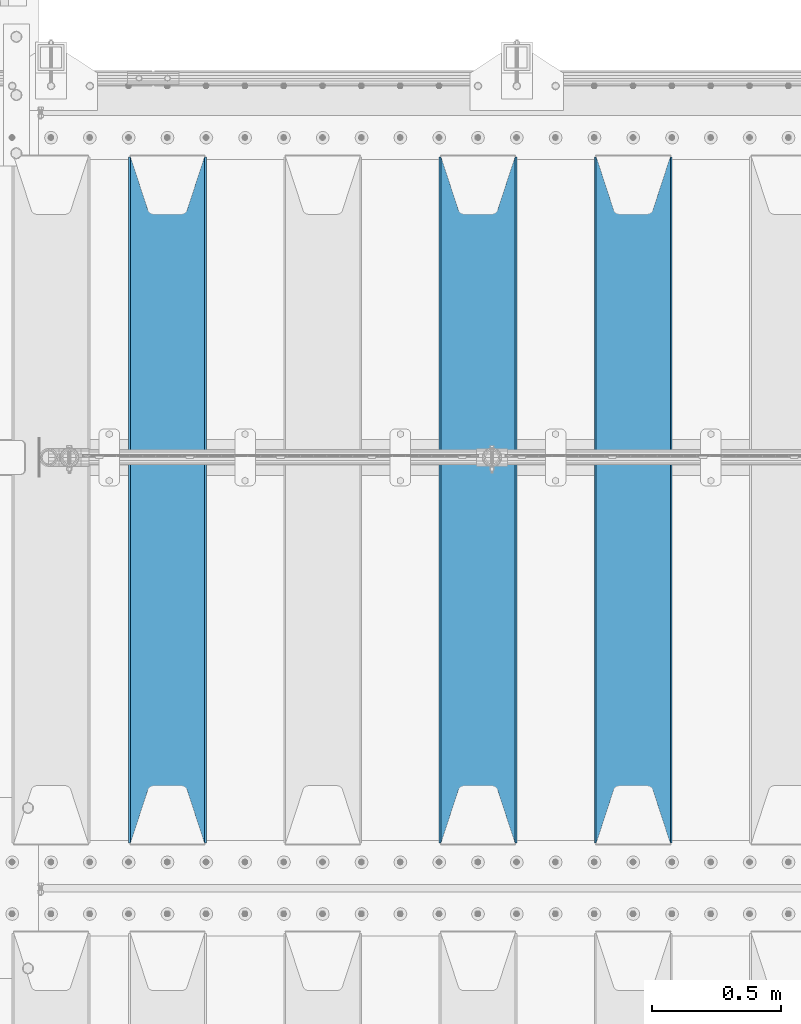
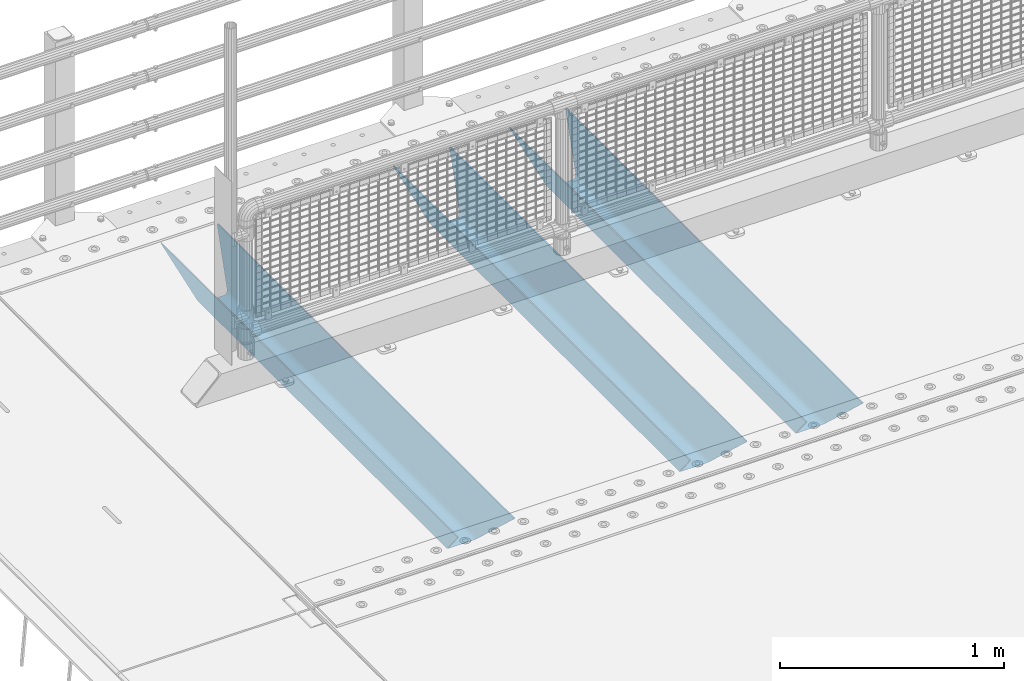
# One storey, part 114 of 242: 3 beams.
"""IFC2X3 building model written with IfcOpenShell, lengths in millimetres."""

from ifc_helpers import new_model, si_unit, frame, origin_with_axes, place, context, subcontext, project, spatial, faceted_brep, material, type_object, element, save


model = new_model("IFC2X3")

# Units and contexts
model_context = context("Model", 3, precision=1e-05, world=origin_with_axes())
body_context = subcontext(model_context, "Body", "Model", "MODEL_VIEW")
ifc_project = project(units=[si_unit("LENGTHUNIT", "METRE", prefix="MILLI"), si_unit("AREAUNIT", "SQUARE_METRE"), si_unit("VOLUMEUNIT", "CUBIC_METRE"), si_unit("MASSUNIT", "GRAM", prefix="KILO"), si_unit("TIMEUNIT", "SECOND"), si_unit("PLANEANGLEUNIT", "RADIAN"), si_unit("SOLIDANGLEUNIT", "STERADIAN"), si_unit("THERMODYNAMICTEMPERATUREUNIT", "DEGREE_CELSIUS"), si_unit("LUMINOUSINTENSITYUNIT", "LUMEN")], contexts=[model_context])

# Site, building, storey
site_placement = place(None, origin_with_axes())
site = spatial("IfcSite", under=ifc_project, at=site_placement, CompositionType="ELEMENT")
building_placement = place(site_placement, origin_with_axes())
building = spatial("IfcBuilding", under=site, at=building_placement, Name="Standard", CompositionType="ELEMENT")
storey_placement = place(building_placement, origin_with_axes())
storey = spatial("IfcBuildingStorey", under=building, at=storey_placement, Name="Undefined", CompositionType="ELEMENT", Elevation=0.0)

# Beams
ifc_material = material(Name="STEEL/S355N")
beam_type = type_object("IfcBeamType", PredefinedType="NOTDEFINED")
beam_1_placement = place(storey_placement, frame((-39650.0, -20825.0, -115.0), z_axis=(0.0, 0.0, 1.0), x_axis=(0.0, 1.0, 0.0)))
element("IfcBeam", 1, at=beam_1_placement, inside=storey, type_object=beam_type, material=ifc_material, context=body_context, shape_type="Brep", body=[
    faceted_brep([(0.0, 150.0, 115.0), (0.0, 143.689999999999, 115.0), (2650.00000000297, 143.689999999999, 115.0), (2650.00000000297, 150.0, 115.0), (2650.00000000297, 142.059565218402, 110.000000003099), (2650.00000000297, 148.369565218403, 110.000000003099), (2441.90079219209, -80.1103600731112, -98.0992078077845), (2437.7588105432, -77.5672621345584, -102.241189456673), (2434.06523489747, -74.4080125315522, -105.934765102404), (2430.91086095089, -70.710272125576, -109.089139048974), (2428.37322971128, -66.5649389910068, -111.626770288588), (2426.51472138055, -62.0739139532889, -113.485278619323), (2425.38102192092, -57.3475956567672, -114.618978078955), (2424.99999999987, -52.5021667386536, -115.0), (2424.99999999987, 52.5021667386536, -115.0), (2425.38102192092, 57.3475956567672, -114.618978078955), (2426.51472138055, 62.0739139532889, -113.485278619323), (2428.37322971128, 66.5649389910068, -111.626770288588), (2430.91086095089, 70.710272125576, -109.089139048974), (2434.06523489747, 74.4080125315522, -105.934765102404), (2437.7588105432, 77.5672621345584, -102.241189456673), (2441.90079219209, 80.1103600731112, -98.0992078077846), (2446.38936140511, 81.9747917625791, -93.6106385947584), (2448.2494850041, 76.2713538057251, -91.7505149957729), (2444.62967112262, 74.76777986261, -95.3703288772456), (2441.28936334126, 72.7168944282894, -98.710636658607), (2438.31067330438, 70.1691124903846, -101.689326695487), (2435.76682334747, 67.1870637758839, -104.233176652398), (2433.72034654133, 63.8440531834895, -106.279653458539), (2432.22154950042, 60.222258798236, -107.778450499454), (2431.30727574265, 56.4107117849089, -108.692724257221), (2430.99999999987, 52.5031078186876, -109.0), (2430.99999999987, -52.5031078186876, -109.0), (2431.30727574265, -56.4107117849089, -108.692724257221), (2432.22154950042, -60.222258798236, -107.778450499454), (2433.72034654133, -63.8440531834895, -106.279653458539), (2435.76682334747, -67.1870637758839, -104.233176652398), (2438.31067330438, -70.1691124903846, -101.689326695487), (2441.28936334126, -72.7168944282894, -98.7106366586071), (2444.62967112262, -74.76777986261, -95.3703288772457), (2448.2494850041, -76.2713538057251, -91.7505149957729), (2650.00000000297, -142.059565218402, 110.000000003099), (2650.00000000297, -148.369565218403, 110.000000003099), (2446.38936140511, -81.9747917625791, -93.6106385947584), (2650.00000000297, -143.689999999999, 115.0), (2650.00000000297, -150.0, 115.0), (0.0, -143.689999999999, 115.0), (0.0, -150.0, 115.0), (0.0, -148.369565218261, 110.000000002669), (203.610638597427, -81.9747917625791, -93.6106385947584), (208.099207810454, -80.1103600731112, -98.0992078077845), (212.241189459342, -77.5672621345584, -102.241189456673), (215.934765105074, -74.4080125315522, -105.934765102404), (219.089139051644, -70.710272125576, -109.089139048974), (221.626770291256, -66.5649389910068, -111.626770288588), (223.485278621993, -62.0739139532889, -113.485278619323), (224.618978081624, -57.3475956567672, -114.618978078955), (225.00000000267, -52.5021667386536, -115.0), (225.00000000267, 52.5021667386536, -115.0), (224.618978081624, 57.3475956567672, -114.618978078955), (223.485278621993, 62.0739139532889, -113.485278619323), (221.626770291256, 66.5649389910068, -111.626770288588), (219.089139051644, 70.710272125576, -109.089139048974), (215.934765105074, 74.4080125315522, -105.934765102404), (212.241189459342, 77.5672621345584, -102.241189456673), (208.099207810454, 80.1103600731112, -98.0992078077846), (203.610638597427, 81.9747917625791, -93.6106385947584), (0.0, 148.369565218261, 110.000000002669), (0.0, 142.05956521826, 110.000000002669), (201.750514998443, 76.2713538057251, -91.7505149957729), (205.370328879915, 74.76777986261, -95.3703288772456), (208.710636661275, 72.7168944282894, -98.710636658607), (211.689326698157, 70.1691124903846, -101.689326695487), (214.233176655067, 67.1870637758839, -104.233176652398), (216.279653461206, 63.8440531834895, -106.279653458539), (217.778450502123, 60.222258798236, -107.778450499454), (218.69272425989, 56.4107117849089, -108.692724257221), (219.00000000267, 52.5031078186876, -109.0), (219.00000000267, -52.5031078186876, -109.0), (218.69272425989, -56.4107117849089, -108.692724257221), (217.778450502123, -60.222258798236, -107.778450499454), (216.279653461206, -63.8440531834895, -106.279653458539), (214.233176655067, -67.1870637758839, -104.233176652398), (211.689326698157, -70.1691124903846, -101.689326695487), (208.710636661275, -72.7168944282894, -98.7106366586071), (205.370328879915, -74.76777986261, -95.3703288772457), (201.750514998443, -76.2713538057251, -91.7505149957729), (0.0, -142.05956521826, 110.000000002669)], [[[0, 1, 2, 3]], [[3, 2, 4, 5]], [[6, 7, 8, 9, 10, 11, 12, 13, 14, 15, 16, 17, 18, 19, 20, 21, 22, 5, 4, 23, 24, 25, 26, 27, 28, 29, 30, 31, 32, 33, 34, 35, 36, 37, 38, 39, 40, 41, 42, 43]], [[44, 45, 42, 41]], [[46, 47, 45, 44]], [[43, 42, 45, 47, 48, 49]], [[6, 43, 49, 50]], [[7, 6, 50, 51]], [[8, 7, 51, 52]], [[9, 8, 52, 53]], [[10, 9, 53, 54]], [[11, 10, 54, 55]], [[12, 11, 55, 56]], [[13, 12, 56, 57]], [[14, 13, 57, 58]], [[15, 14, 58, 59]], [[16, 15, 59, 60]], [[17, 16, 60, 61]], [[18, 17, 61, 62]], [[19, 18, 62, 63]], [[20, 19, 63, 64]], [[21, 20, 64, 65]], [[22, 21, 65, 66]], [[0, 3, 5, 22, 66, 67]], [[1, 0, 67, 68]], [[23, 4, 2, 1, 68, 69]], [[24, 23, 69, 70]], [[25, 24, 70, 71]], [[26, 25, 71, 72]], [[27, 26, 72, 73]], [[28, 27, 73, 74]], [[29, 28, 74, 75]], [[30, 29, 75, 76]], [[31, 30, 76, 77]], [[32, 31, 77, 78]], [[33, 32, 78, 79]], [[34, 33, 79, 80]], [[35, 34, 80, 81]], [[36, 35, 81, 82]], [[37, 36, 82, 83]], [[38, 37, 83, 84]], [[39, 38, 84, 85]], [[40, 39, 85, 86]], [[46, 44, 41, 40, 86, 87]], [[47, 46, 87, 48]], [[86, 85, 84, 83, 82, 81, 80, 79, 78, 77, 76, 75, 74, 73, 72, 71, 70, 69, 68, 67, 66, 65, 64, 63, 62, 61, 60, 59, 58, 57, 56, 55, 54, 53, 52, 51, 50, 49, 48, 87]]]),
])
beam_2_placement = place(storey_placement, frame((-40250.0, -20825.0, -115.0), z_axis=(0.0, 0.0, 1.0), x_axis=(0.0, 1.0, 0.0)))
element("IfcBeam", 2, at=beam_2_placement, inside=storey, type_object=beam_type, material=ifc_material, context=body_context, shape_type="Brep", body=[
    faceted_brep([(0.0, 150.0, 115.0), (0.0, 143.689999999999, 115.0), (2650.00000000297, 143.689999999999, 115.0), (2650.00000000297, 150.0, 115.0), (2650.00000000297, 142.059565218402, 110.000000003099), (2650.00000000297, 148.369565218403, 110.000000003099), (2441.90079219209, -80.1103600731112, -98.0992078077845), (2437.7588105432, -77.5672621345584, -102.241189456673), (2434.06523489747, -74.4080125315522, -105.934765102404), (2430.91086095089, -70.710272125576, -109.089139048974), (2428.37322971128, -66.5649389910068, -111.626770288588), (2426.51472138055, -62.0739139532889, -113.485278619323), (2425.38102192092, -57.3475956567672, -114.618978078955), (2424.99999999987, -52.5021667386536, -115.0), (2424.99999999987, 52.5021667386536, -115.0), (2425.38102192092, 57.3475956567672, -114.618978078955), (2426.51472138055, 62.0739139532889, -113.485278619323), (2428.37322971128, 66.5649389910068, -111.626770288588), (2430.91086095089, 70.710272125576, -109.089139048974), (2434.06523489747, 74.4080125315522, -105.934765102404), (2437.7588105432, 77.5672621345584, -102.241189456673), (2441.90079219209, 80.1103600731112, -98.0992078077846), (2446.38936140511, 81.9747917625791, -93.6106385947584), (2448.2494850041, 76.2713538057251, -91.7505149957729), (2444.62967112262, 74.76777986261, -95.3703288772456), (2441.28936334126, 72.7168944282894, -98.710636658607), (2438.31067330438, 70.1691124903846, -101.689326695487), (2435.76682334747, 67.1870637758839, -104.233176652398), (2433.72034654133, 63.8440531834895, -106.279653458539), (2432.22154950042, 60.222258798236, -107.778450499454), (2431.30727574265, 56.4107117849089, -108.692724257221), (2430.99999999987, 52.5031078186876, -109.0), (2430.99999999987, -52.5031078186876, -109.0), (2431.30727574265, -56.4107117849089, -108.692724257221), (2432.22154950042, -60.222258798236, -107.778450499454), (2433.72034654133, -63.8440531834895, -106.279653458539), (2435.76682334747, -67.1870637758839, -104.233176652398), (2438.31067330438, -70.1691124903846, -101.689326695487), (2441.28936334126, -72.7168944282894, -98.7106366586071), (2444.62967112262, -74.76777986261, -95.3703288772457), (2448.2494850041, -76.2713538057251, -91.7505149957729), (2650.00000000297, -142.059565218402, 110.000000003099), (2650.00000000297, -148.369565218403, 110.000000003099), (2446.38936140511, -81.9747917625791, -93.6106385947584), (2650.00000000297, -143.689999999999, 115.0), (2650.00000000297, -150.0, 115.0), (0.0, -143.689999999999, 115.0), (0.0, -150.0, 115.0), (0.0, -148.369565218261, 110.000000002669), (203.610638597427, -81.9747917625791, -93.6106385947584), (208.099207810454, -80.1103600731112, -98.0992078077845), (212.241189459342, -77.5672621345584, -102.241189456673), (215.934765105074, -74.4080125315522, -105.934765102404), (219.089139051644, -70.710272125576, -109.089139048974), (221.626770291256, -66.5649389910068, -111.626770288588), (223.485278621993, -62.0739139532889, -113.485278619323), (224.618978081624, -57.3475956567672, -114.618978078955), (225.00000000267, -52.5021667386536, -115.0), (225.00000000267, 52.5021667386536, -115.0), (224.618978081624, 57.3475956567672, -114.618978078955), (223.485278621993, 62.0739139532889, -113.485278619323), (221.626770291256, 66.5649389910068, -111.626770288588), (219.089139051644, 70.710272125576, -109.089139048974), (215.934765105074, 74.4080125315522, -105.934765102404), (212.241189459342, 77.5672621345584, -102.241189456673), (208.099207810454, 80.1103600731112, -98.0992078077846), (203.610638597427, 81.9747917625791, -93.6106385947584), (0.0, 148.369565218261, 110.000000002669), (0.0, 142.05956521826, 110.000000002669), (201.750514998443, 76.2713538057251, -91.7505149957729), (205.370328879915, 74.76777986261, -95.3703288772456), (208.710636661275, 72.7168944282894, -98.710636658607), (211.689326698157, 70.1691124903846, -101.689326695487), (214.233176655067, 67.1870637758839, -104.233176652398), (216.279653461206, 63.8440531834895, -106.279653458539), (217.778450502123, 60.222258798236, -107.778450499454), (218.69272425989, 56.4107117849089, -108.692724257221), (219.00000000267, 52.5031078186876, -109.0), (219.00000000267, -52.5031078186876, -109.0), (218.69272425989, -56.4107117849089, -108.692724257221), (217.778450502123, -60.222258798236, -107.778450499454), (216.279653461206, -63.8440531834895, -106.279653458539), (214.233176655067, -67.1870637758839, -104.233176652398), (211.689326698157, -70.1691124903846, -101.689326695487), (208.710636661275, -72.7168944282894, -98.7106366586071), (205.370328879915, -74.76777986261, -95.3703288772457), (201.750514998443, -76.2713538057251, -91.7505149957729), (0.0, -142.05956521826, 110.000000002669)], [[[0, 1, 2, 3]], [[3, 2, 4, 5]], [[6, 7, 8, 9, 10, 11, 12, 13, 14, 15, 16, 17, 18, 19, 20, 21, 22, 5, 4, 23, 24, 25, 26, 27, 28, 29, 30, 31, 32, 33, 34, 35, 36, 37, 38, 39, 40, 41, 42, 43]], [[44, 45, 42, 41]], [[46, 47, 45, 44]], [[43, 42, 45, 47, 48, 49]], [[6, 43, 49, 50]], [[7, 6, 50, 51]], [[8, 7, 51, 52]], [[9, 8, 52, 53]], [[10, 9, 53, 54]], [[11, 10, 54, 55]], [[12, 11, 55, 56]], [[13, 12, 56, 57]], [[14, 13, 57, 58]], [[15, 14, 58, 59]], [[16, 15, 59, 60]], [[17, 16, 60, 61]], [[18, 17, 61, 62]], [[19, 18, 62, 63]], [[20, 19, 63, 64]], [[21, 20, 64, 65]], [[22, 21, 65, 66]], [[0, 3, 5, 22, 66, 67]], [[1, 0, 67, 68]], [[23, 4, 2, 1, 68, 69]], [[24, 23, 69, 70]], [[25, 24, 70, 71]], [[26, 25, 71, 72]], [[27, 26, 72, 73]], [[28, 27, 73, 74]], [[29, 28, 74, 75]], [[30, 29, 75, 76]], [[31, 30, 76, 77]], [[32, 31, 77, 78]], [[33, 32, 78, 79]], [[34, 33, 79, 80]], [[35, 34, 80, 81]], [[36, 35, 81, 82]], [[37, 36, 82, 83]], [[38, 37, 83, 84]], [[39, 38, 84, 85]], [[40, 39, 85, 86]], [[46, 44, 41, 40, 86, 87]], [[47, 46, 87, 48]], [[86, 85, 84, 83, 82, 81, 80, 79, 78, 77, 76, 75, 74, 73, 72, 71, 70, 69, 68, 67, 66, 65, 64, 63, 62, 61, 60, 59, 58, 57, 56, 55, 54, 53, 52, 51, 50, 49, 48, 87]]]),
])
beam_3_placement = place(storey_placement, frame((-41450.0, -20825.0, -115.0), z_axis=(0.0, 0.0, 1.0), x_axis=(0.0, 1.0, 0.0)))
element("IfcBeam", 3, at=beam_3_placement, inside=storey, type_object=beam_type, material=ifc_material, context=body_context, shape_type="Brep", body=[
    faceted_brep([(0.0, 150.0, 115.0), (0.0, 143.689999999999, 115.0), (2650.00000000297, 143.689999999999, 115.0), (2650.00000000297, 150.0, 115.0), (2650.00000000297, 142.059565218402, 110.000000003099), (2650.00000000297, 148.369565218403, 110.000000003099), (2441.90079219209, -80.1103600731112, -98.0992078077845), (2437.7588105432, -77.5672621345584, -102.241189456673), (2434.06523489747, -74.4080125315522, -105.934765102404), (2430.91086095089, -70.710272125576, -109.089139048974), (2428.37322971128, -66.5649389910068, -111.626770288588), (2426.51472138055, -62.0739139532889, -113.485278619323), (2425.38102192092, -57.3475956567672, -114.618978078955), (2424.99999999987, -52.5021667386536, -115.0), (2424.99999999987, 52.5021667386536, -115.0), (2425.38102192092, 57.3475956567672, -114.618978078955), (2426.51472138055, 62.0739139532889, -113.485278619323), (2428.37322971128, 66.5649389910068, -111.626770288588), (2430.91086095089, 70.710272125576, -109.089139048974), (2434.06523489747, 74.4080125315522, -105.934765102404), (2437.7588105432, 77.5672621345584, -102.241189456673), (2441.90079219209, 80.1103600731112, -98.0992078077846), (2446.38936140511, 81.9747917625791, -93.6106385947584), (2448.2494850041, 76.2713538057251, -91.7505149957729), (2444.62967112262, 74.76777986261, -95.3703288772456), (2441.28936334126, 72.7168944282894, -98.710636658607), (2438.31067330438, 70.1691124903846, -101.689326695487), (2435.76682334747, 67.1870637758839, -104.233176652398), (2433.72034654133, 63.8440531834895, -106.279653458539), (2432.22154950042, 60.222258798236, -107.778450499454), (2431.30727574265, 56.4107117849089, -108.692724257221), (2430.99999999987, 52.5031078186876, -109.0), (2430.99999999987, -52.5031078186876, -109.0), (2431.30727574265, -56.4107117849089, -108.692724257221), (2432.22154950042, -60.222258798236, -107.778450499454), (2433.72034654133, -63.8440531834895, -106.279653458539), (2435.76682334747, -67.1870637758839, -104.233176652398), (2438.31067330438, -70.1691124903846, -101.689326695487), (2441.28936334126, -72.7168944282894, -98.7106366586071), (2444.62967112262, -74.76777986261, -95.3703288772457), (2448.2494850041, -76.2713538057251, -91.7505149957729), (2650.00000000297, -142.059565218402, 110.000000003099), (2650.00000000297, -148.369565218403, 110.000000003099), (2446.38936140511, -81.9747917625791, -93.6106385947584), (2650.00000000297, -143.689999999999, 115.0), (2650.00000000297, -150.0, 115.0), (0.0, -143.689999999999, 115.0), (0.0, -150.0, 115.0), (0.0, -148.369565218261, 110.000000002669), (203.610638597427, -81.9747917625791, -93.6106385947584), (208.099207810454, -80.1103600731112, -98.0992078077845), (212.241189459342, -77.5672621345584, -102.241189456673), (215.934765105074, -74.4080125315522, -105.934765102404), (219.089139051644, -70.710272125576, -109.089139048974), (221.626770291256, -66.5649389910068, -111.626770288588), (223.485278621993, -62.0739139532889, -113.485278619323), (224.618978081624, -57.3475956567672, -114.618978078955), (225.00000000267, -52.5021667386536, -115.0), (225.00000000267, 52.5021667386536, -115.0), (224.618978081624, 57.3475956567672, -114.618978078955), (223.485278621993, 62.0739139532889, -113.485278619323), (221.626770291256, 66.5649389910068, -111.626770288588), (219.089139051644, 70.710272125576, -109.089139048974), (215.934765105074, 74.4080125315522, -105.934765102404), (212.241189459342, 77.5672621345584, -102.241189456673), (208.099207810454, 80.1103600731112, -98.0992078077846), (203.610638597427, 81.9747917625791, -93.6106385947584), (0.0, 148.369565218261, 110.000000002669), (0.0, 142.05956521826, 110.000000002669), (201.750514998443, 76.2713538057251, -91.7505149957729), (205.370328879915, 74.76777986261, -95.3703288772456), (208.710636661275, 72.7168944282894, -98.710636658607), (211.689326698157, 70.1691124903846, -101.689326695487), (214.233176655067, 67.1870637758839, -104.233176652398), (216.279653461206, 63.8440531834895, -106.279653458539), (217.778450502123, 60.222258798236, -107.778450499454), (218.69272425989, 56.4107117849089, -108.692724257221), (219.00000000267, 52.5031078186876, -109.0), (219.00000000267, -52.5031078186876, -109.0), (218.69272425989, -56.4107117849089, -108.692724257221), (217.778450502123, -60.222258798236, -107.778450499454), (216.279653461206, -63.8440531834895, -106.279653458539), (214.233176655067, -67.1870637758839, -104.233176652398), (211.689326698157, -70.1691124903846, -101.689326695487), (208.710636661275, -72.7168944282894, -98.7106366586071), (205.370328879915, -74.76777986261, -95.3703288772457), (201.750514998443, -76.2713538057251, -91.7505149957729), (0.0, -142.05956521826, 110.000000002669)], [[[0, 1, 2, 3]], [[3, 2, 4, 5]], [[6, 7, 8, 9, 10, 11, 12, 13, 14, 15, 16, 17, 18, 19, 20, 21, 22, 5, 4, 23, 24, 25, 26, 27, 28, 29, 30, 31, 32, 33, 34, 35, 36, 37, 38, 39, 40, 41, 42, 43]], [[44, 45, 42, 41]], [[46, 47, 45, 44]], [[43, 42, 45, 47, 48, 49]], [[6, 43, 49, 50]], [[7, 6, 50, 51]], [[8, 7, 51, 52]], [[9, 8, 52, 53]], [[10, 9, 53, 54]], [[11, 10, 54, 55]], [[12, 11, 55, 56]], [[13, 12, 56, 57]], [[14, 13, 57, 58]], [[15, 14, 58, 59]], [[16, 15, 59, 60]], [[17, 16, 60, 61]], [[18, 17, 61, 62]], [[19, 18, 62, 63]], [[20, 19, 63, 64]], [[21, 20, 64, 65]], [[22, 21, 65, 66]], [[0, 3, 5, 22, 66, 67]], [[1, 0, 67, 68]], [[23, 4, 2, 1, 68, 69]], [[24, 23, 69, 70]], [[25, 24, 70, 71]], [[26, 25, 71, 72]], [[27, 26, 72, 73]], [[28, 27, 73, 74]], [[29, 28, 74, 75]], [[30, 29, 75, 76]], [[31, 30, 76, 77]], [[32, 31, 77, 78]], [[33, 32, 78, 79]], [[34, 33, 79, 80]], [[35, 34, 80, 81]], [[36, 35, 81, 82]], [[37, 36, 82, 83]], [[38, 37, 83, 84]], [[39, 38, 84, 85]], [[40, 39, 85, 86]], [[46, 44, 41, 40, 86, 87]], [[47, 46, 87, 48]], [[86, 85, 84, 83, 82, 81, 80, 79, 78, 77, 76, 75, 74, 73, 72, 71, 70, 69, 68, 67, 66, 65, 64, 63, 62, 61, 60, 59, 58, 57, 56, 55, 54, 53, 52, 51, 50, 49, 48, 87]]]),
])

save(model, "model.ifc")
